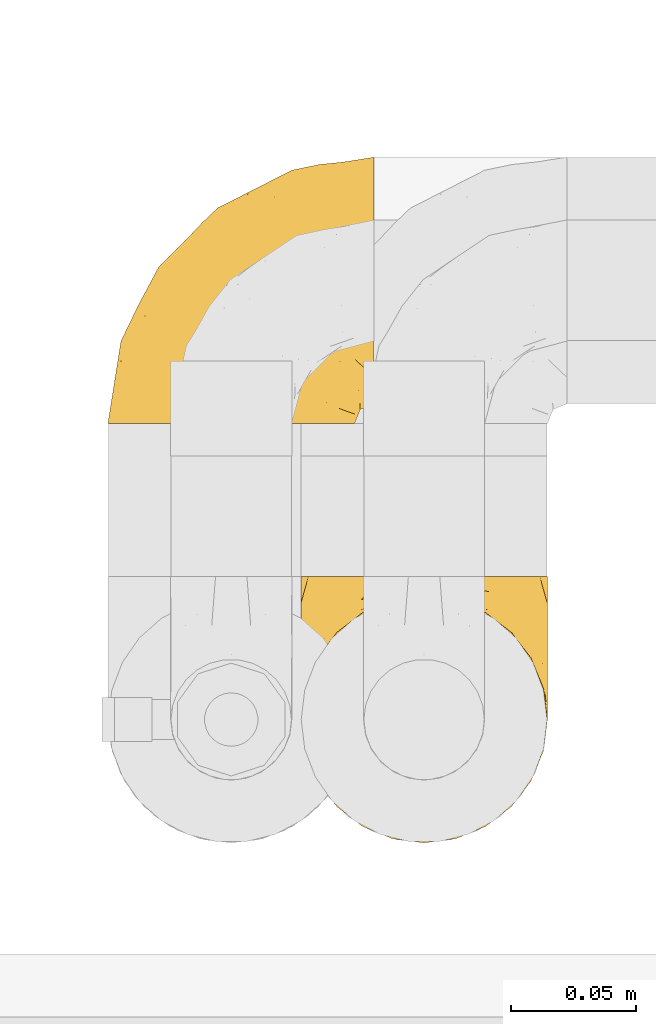
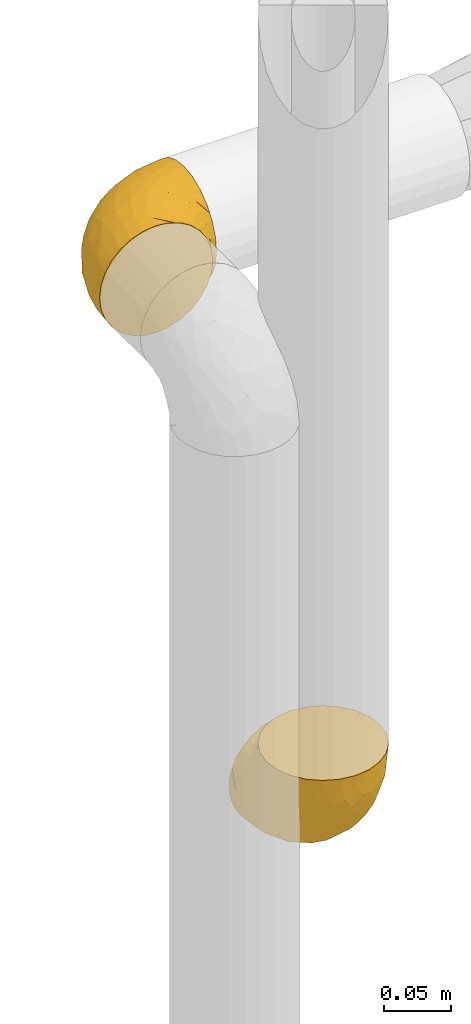
# One storey, part 409 of 827: 2 coverings.
"""IFC2X3 building model written with IfcOpenShell, lengths in millimetres."""

from ifc_helpers import new_model, entity, si_unit, converted_unit, derived_unit, direction, frame, origin, place, context, subcontext, project, spatial, faceted_brep, element, save


model = new_model("IFC2X3")

# Units and contexts
model_context = context("Model", 3, precision=0.01, world=origin(), true_north=direction((6.12303176911189e-17, 1.0)))
body_context = subcontext(model_context, "Body", "Model", "MODEL_VIEW")
ifc_project = project(units=[si_unit("LENGTHUNIT", "METRE", prefix="MILLI"), si_unit("AREAUNIT", "SQUARE_METRE"), si_unit("VOLUMEUNIT", "CUBIC_METRE"), converted_unit("PLANEANGLEUNIT", "DEGREE", entity("IfcRatioMeasure", 0.0174532925199433), si_unit("PLANEANGLEUNIT", "RADIAN"), dimensions=[0, 0, 0, 0, 0, 0, 0]), si_unit("MASSUNIT", "GRAM", prefix="KILO"), derived_unit("MASSDENSITYUNIT", [(si_unit("MASSUNIT", "GRAM", prefix="KILO"), 1), (si_unit("LENGTHUNIT", "METRE"), -3)]), derived_unit("MOMENTOFINERTIAUNIT", [(si_unit("LENGTHUNIT", "METRE"), 4)]), si_unit("TIMEUNIT", "SECOND"), si_unit("FREQUENCYUNIT", "HERTZ"), si_unit("THERMODYNAMICTEMPERATUREUNIT", "DEGREE_CELSIUS"), derived_unit("THERMALTRANSMITTANCEUNIT", [(si_unit("MASSUNIT", "GRAM", prefix="KILO"), 1), (si_unit("THERMODYNAMICTEMPERATUREUNIT", "KELVIN"), -1), (si_unit("TIMEUNIT", "SECOND"), -3)]), derived_unit("VOLUMETRICFLOWRATEUNIT", [(si_unit("LENGTHUNIT", "METRE"), 3), (si_unit("TIMEUNIT", "SECOND"), -1)]), derived_unit("MASSFLOWRATEUNIT", [(si_unit("MASSUNIT", "GRAM", prefix="KILO"), 1), (si_unit("TIMEUNIT", "SECOND"), -1)]), derived_unit("ROTATIONALFREQUENCYUNIT", [(si_unit("TIMEUNIT", "SECOND"), -1)]), si_unit("ELECTRICCURRENTUNIT", "AMPERE"), si_unit("ELECTRICVOLTAGEUNIT", "VOLT"), si_unit("POWERUNIT", "WATT"), si_unit("FORCEUNIT", "NEWTON", prefix="KILO"), si_unit("ILLUMINANCEUNIT", "LUX"), si_unit("LUMINOUSFLUXUNIT", "LUMEN"), si_unit("LUMINOUSINTENSITYUNIT", "CANDELA"), derived_unit("USERDEFINED", [(si_unit("MASSUNIT", "GRAM", prefix="KILO"), -1), (si_unit("LENGTHUNIT", "METRE"), -2), (si_unit("TIMEUNIT", "SECOND"), 3), (si_unit("LUMINOUSFLUXUNIT", "LUMEN"), 1)]), derived_unit("LINEARVELOCITYUNIT", [(si_unit("LENGTHUNIT", "METRE"), 1), (si_unit("TIMEUNIT", "SECOND"), -1)]), si_unit("PRESSUREUNIT", "PASCAL"), derived_unit("USERDEFINED", [(si_unit("LENGTHUNIT", "METRE"), -2), (si_unit("MASSUNIT", "GRAM", prefix="KILO"), 1), (si_unit("TIMEUNIT", "SECOND"), -2)]), derived_unit("LINEARFORCEUNIT", [(si_unit("MASSUNIT", "GRAM", prefix="KILO"), 1), (si_unit("LENGTHUNIT", "METRE"), 1), (si_unit("TIMEUNIT", "SECOND"), -2), (si_unit("LENGTHUNIT", "METRE"), -1)]), derived_unit("PLANARFORCEUNIT", [(si_unit("MASSUNIT", "GRAM", prefix="KILO"), 1), (si_unit("LENGTHUNIT", "METRE"), 1), (si_unit("TIMEUNIT", "SECOND"), -2), (si_unit("LENGTHUNIT", "METRE"), -2)])], contexts=[model_context])

# Site, building, storey
site_placement = place(None, origin())
site = spatial("IfcSite", under=ifc_project, at=site_placement, CompositionType="ELEMENT")
building_placement = place(site_placement, origin())
building = spatial("IfcBuilding", under=site, at=building_placement, CompositionType="ELEMENT")
storey_placement = place(building_placement, frame((0.0, 0.0, 28200.0)))
storey = spatial("IfcBuildingStorey", under=building, at=storey_placement, Name="08", CompositionType="ELEMENT", Elevation=28200.0)

# Coverings
covering_1_placement = place(storey_placement, frame((47610.43, 18915.48, 811.13)))
element("IfcCovering", 1, at=covering_1_placement, inside=storey, Name=":ADSK_", ObjectType=":ADSK_", PredefinedType="INSULATION", context=body_context, shape_type="Brep", body=[
    faceted_brep([(99.9, 107.75, 50.75), (98.66, 107.75, 39.8), (95.02, 107.75, 29.41), (89.17, 107.75, 20.09), (81.38, 107.75, 12.31), (72.06, 107.75, 6.46), (61.68, 107.75, 2.83), (50.75, 107.75, 1.6), (39.8, 107.75, 2.83), (29.41, 107.75, 6.47), (20.09, 107.75, 12.32), (12.31, 107.75, 20.11), (6.46, 107.75, 29.43), (2.83, 107.75, 39.81), (1.6, 107.75, 50.75), (2.24, 107.75, 56.45), (2.83, 107.75, 61.69), (4.65, 107.75, 66.88), (6.47, 107.75, 72.08), (12.32, 107.75, 81.4), (20.11, 107.75, 89.18), (29.43, 107.75, 95.03), (39.81, 107.75, 98.66), (50.75, 107.75, 99.9), (61.69, 107.75, 98.66), (72.08, 107.75, 95.02), (81.4, 107.75, 89.17), (89.18, 107.75, 81.38), (95.03, 107.75, 72.06), (96.85, 107.75, 66.87), (98.66, 107.75, 61.68), (99.25, 107.75, 56.45), (99.57, 107.75, 53.6), (38.02, 98.22, 107.75), (26.17, 93.31, 107.75), (21.08, 89.4, 107.75), (15.99, 85.5, 107.75), (12.09, 80.41, 107.75), (8.18, 75.32, 107.75), (5.73, 69.39, 107.75), (3.27, 63.47, 107.75), (2.35, 56.48, 107.75), (1.97, 53.61, 107.75), (1.6, 50.75, 107.75), (3.27, 38.02, 107.75), (8.18, 26.17, 107.75), (15.99, 15.99, 107.75), (26.17, 8.18, 107.75), (38.02, 3.27, 107.75), (50.75, 1.6, 107.75), (63.47, 3.27, 107.75), (75.32, 8.18, 107.75), (85.5, 15.99, 107.75), (93.31, 26.17, 107.75), (98.22, 38.02, 107.75), (99.9, 50.75, 107.75), (99.14, 56.48, 107.75), (98.22, 63.47, 107.75), (95.77, 69.39, 107.75), (93.31, 75.32, 107.75), (89.4, 80.41, 107.75), (85.5, 85.5, 107.75), (80.41, 89.4, 107.75), (75.32, 93.31, 107.75), (63.47, 98.22, 107.75), (50.75, 99.9, 107.75), (59.31, 27.53, 39.38), (73.08, 25.32, 49.75), (63.72, 16.29, 57.38), (50.75, 6.79, 74.94), (58.64, 4.51, 85.97), (50.75, 3.51, 95.66), (76.74, 17.47, 67.82), (67.68, 7.6, 83.09), (78.92, 12.27, 89.16), (94.31, 70.89, 37.01), (98.76, 87.17, 43.46), (98.4, 67.3, 51.79), (94.57, 31.65, 85.58), (89.91, 33.58, 62.84), (96.32, 47.23, 62.77), (98.79, 43.26, 88.17), (99.9, 55.08, 85.93), (99.9, 53.99, 91.42), (99.9, 52.9, 96.91), (99.9, 52.36, 99.62), (99.9, 51.82, 102.33), (87.31, 21.5, 82.57), (95.61, 89.94, 32.75), (60.43, 60.45, 13.79), (65.24, 83.0, 6.77), (72.87, 64.79, 16.46), (99.9, 85.93, 55.08), (99.9, 81.31, 58.17), (99.9, 76.69, 61.26), (99.9, 72.06, 64.35), (99.9, 67.44, 67.44), (90.65, 88.74, 24.18), (63.14, 45.98, 23.37), (91.89, 47.13, 49.76), (75.25, 89.4, 9.84), (50.75, 95.66, 3.51), (82.18, 28.5, 55.75), (85.08, 42.81, 42.34), (76.93, 38.28, 37.78), (50.75, 45.35, 21.87), (50.75, 33.61, 33.61), (83.02, 82.57, 17.1), (99.9, 105.04, 51.28), (99.9, 102.33, 51.82), (99.9, 96.91, 52.9), (99.9, 91.42, 53.99), (87.13, 65.92, 28.01), (80.85, 53.11, 28.99), (99.17, 54.37, 69.9), (50.75, 74.94, 6.79), (99.9, 64.35, 72.06), (99.9, 61.26, 76.69), (99.9, 58.17, 81.31), (50.75, 21.87, 45.35), (67.61, 34.79, 34.79), (72.25, 48.48, 25.72), (50.75, 60.15, 14.33), (50.75, 14.33, 60.15), (98.69, 99.07, 62.38), (99.01, 60.55, 100.57), (98.79, 64.18, 91.06), (98.29, 64.36, 97.66), (68.51, 103.17, 97.55), (76.82, 101.69, 93.65), (98.54, 87.75, 66.85), (99.3, 89.38, 61.93), (83.57, 88.34, 101.4), (89.47, 82.14, 100.07), (75.76, 94.51, 101.36), (84.86, 89.64, 95.94), (75.89, 98.41, 96.3), (64.77, 99.71, 101.98), (90.83, 89.37, 85.88), (94.62, 88.21, 78.88), (90.37, 95.2, 82.8), (91.18, 79.14, 102.58), (88.65, 101.22, 82.88), (84.11, 99.41, 88.57), (91.75, 84.72, 88.67), (96.86, 97.47, 69.08), (50.75, 102.19, 102.19), (58.97, 104.02, 100.06), (98.37, 82.66, 70.56), (83.91, 95.42, 91.07), (97.52, 78.67, 77.56), (95.55, 72.69, 96.59), (98.76, 66.46, 86.38), (95.26, 75.3, 91.79), (98.04, 72.74, 81.71), (90.65, 82.93, 94.11), (93.51, 99.27, 76.09), (94.16, 93.51, 76.91), (99.1, 67.35, 81.44), (25.73, 94.51, 101.37), (10.84, 82.94, 94.12), (17.92, 88.33, 101.41), (16.64, 89.64, 95.96), (30.44, 103.62, 96.22), (2.95, 87.74, 66.85), (2.19, 89.38, 61.94), (1.6, 81.31, 58.17), (4.63, 97.47, 69.1), (17.39, 99.41, 88.58), (1.6, 52.9, 96.91), (1.6, 51.82, 102.33), (1.6, 51.28, 105.04), (12.86, 101.21, 82.9), (11.13, 95.19, 82.82), (3.2, 64.36, 97.66), (5.94, 72.69, 96.59), (12.02, 82.13, 100.07), (6.23, 75.3, 91.79), (10.31, 79.14, 102.58), (8.0, 99.28, 76.13), (7.34, 93.51, 76.93), (2.48, 60.55, 100.57), (2.73, 66.46, 86.38), (2.64, 63.96, 90.86), (1.6, 96.91, 52.9), (2.8, 99.06, 62.39), (36.71, 99.7, 101.98), (1.6, 53.99, 91.42), (1.6, 55.08, 85.93), (38.59, 103.3, 99.49), (1.6, 102.33, 51.82), (1.6, 99.62, 52.36), (1.6, 76.69, 61.26), (3.12, 82.66, 70.56), (17.59, 95.42, 91.09), (1.6, 72.06, 64.35), (3.98, 78.68, 77.6), (6.87, 88.2, 78.89), (3.45, 72.75, 81.71), (9.76, 84.74, 88.69), (1.6, 91.42, 53.99), (1.6, 85.93, 55.08), (25.62, 98.41, 96.31), (10.67, 89.37, 85.9), (2.39, 67.35, 81.45), (1.6, 61.26, 76.69), (1.6, 58.17, 81.31), (1.6, 64.35, 72.06), (1.6, 67.44, 67.44), (2.4, 54.08, 69.6), (42.85, 4.51, 85.97), (14.18, 21.5, 82.57), (11.56, 33.43, 63.16), (19.27, 28.5, 55.81), (24.75, 17.47, 67.81), (28.37, 25.36, 49.73), (5.95, 90.18, 32.55), (2.79, 86.97, 43.23), (2.71, 43.26, 88.17), (37.78, 16.29, 57.38), (33.81, 7.6, 83.08), (22.57, 12.27, 89.16), (6.92, 31.65, 85.58), (28.61, 64.79, 16.46), (36.24, 83.0, 6.77), (41.05, 60.44, 13.8), (24.55, 38.35, 37.71), (33.88, 34.8, 34.8), (7.11, 71.54, 36.83), (42.18, 27.53, 39.38), (18.46, 82.57, 17.12), (10.84, 88.74, 24.19), (20.69, 53.19, 28.89), (29.27, 48.49, 25.69), (3.1, 67.28, 51.77), (9.18, 52.32, 45.66), (38.38, 45.94, 23.39), (26.23, 89.4, 9.85), (14.34, 65.75, 28.11), (5.46, 46.73, 62.27), (16.39, 42.82, 42.35)], [[[0, 1, 2, 3, 4, 5, 6, 7, 8, 9, 10, 11, 12, 13, 14, 15, 16, 17, 18, 19, 20, 21, 22, 23, 24, 25, 26, 27, 28, 29, 30, 31, 32]], [[33, 34, 35, 36, 37, 38, 39, 40, 41, 42, 43, 44, 45, 46, 47, 48, 49, 50, 51, 52, 53, 54, 55, 56, 57, 58, 59, 60, 61, 62, 63, 64, 65]], [[66, 67, 68]], [[69, 70, 71]], [[68, 72, 73]], [[73, 72, 74]], [[75, 76, 77]], [[78, 79, 80]], [[51, 50, 73]], [[81, 82, 83, 84, 85, 86, 55]], [[52, 87, 53]], [[74, 52, 51]], [[2, 1, 88]], [[89, 90, 91]], [[77, 92, 93, 94, 95, 96]], [[55, 54, 81]], [[78, 53, 87]], [[5, 90, 6]], [[88, 76, 75]], [[97, 3, 2]], [[89, 91, 98]], [[99, 80, 79]], [[90, 5, 100]], [[74, 87, 52]], [[100, 5, 4]], [[90, 101, 6]], [[79, 102, 103]], [[102, 67, 104]], [[105, 98, 106]], [[107, 4, 3]], [[76, 0, 108, 109, 110, 111, 92]], [[107, 112, 113]], [[114, 77, 96]], [[89, 115, 90]], [[114, 96, 116, 117, 118, 82]], [[75, 97, 88]], [[119, 66, 68]], [[50, 71, 70]], [[100, 91, 90]], [[99, 77, 80]], [[102, 104, 103]], [[97, 107, 3]], [[80, 81, 78]], [[107, 97, 112]], [[68, 73, 70]], [[66, 98, 120]], [[78, 81, 54]], [[114, 81, 80]], [[53, 78, 54]], [[78, 87, 79]], [[102, 87, 72]], [[79, 103, 99]], [[4, 107, 100]], [[91, 100, 107]], [[88, 97, 2]], [[112, 97, 75]], [[99, 112, 75]], [[103, 104, 113]], [[91, 121, 98]], [[89, 105, 122, 115]], [[101, 90, 115]], [[101, 7, 6]], [[88, 1, 76]], [[0, 76, 1]], [[92, 77, 76]], [[73, 74, 51]], [[87, 74, 72]], [[81, 114, 82]], [[77, 114, 80]], [[87, 102, 79]], [[67, 102, 72]], [[68, 67, 72]], [[67, 120, 104]], [[120, 121, 104]], [[104, 121, 113]], [[121, 120, 98]], [[91, 107, 113]], [[91, 113, 121]], [[103, 113, 112]], [[66, 119, 106]], [[105, 89, 98]], [[68, 69, 123, 119]], [[98, 66, 106]], [[66, 120, 67]], [[50, 49, 71]], [[50, 70, 73]], [[112, 99, 103]], [[77, 99, 75]], [[69, 68, 70]], [[29, 124, 110]], [[84, 83, 125]], [[126, 82, 118]], [[59, 58, 127]], [[25, 128, 129]], [[130, 93, 131]], [[132, 62, 133]], [[134, 135, 136]], [[137, 65, 64]], [[64, 134, 137]], [[138, 139, 140]], [[111, 110, 124, 92]], [[134, 136, 137]], [[134, 64, 63]], [[133, 61, 141]], [[125, 58, 57]], [[142, 143, 140]], [[142, 26, 143]], [[127, 83, 82]], [[28, 124, 29]], [[108, 0, 32, 31, 30, 110, 109]], [[30, 29, 110]], [[135, 144, 138]], [[28, 145, 124]], [[57, 56, 55, 86, 85, 84]], [[146, 147, 23]], [[24, 23, 147]], [[25, 143, 26]], [[95, 94, 148]], [[24, 128, 25]], [[149, 138, 143]], [[124, 145, 131]], [[127, 58, 125]], [[150, 148, 139]], [[127, 126, 151]], [[151, 59, 127]], [[152, 151, 126]], [[153, 154, 155]], [[153, 133, 141]], [[145, 28, 27]], [[142, 156, 27]], [[157, 148, 130]], [[61, 133, 62]], [[134, 132, 135]], [[147, 128, 24]], [[65, 137, 146]], [[146, 137, 147]], [[128, 137, 136]], [[137, 128, 147]], [[128, 136, 129]], [[149, 129, 136]], [[25, 129, 143]], [[158, 152, 117]], [[152, 118, 117]], [[153, 151, 152]], [[158, 116, 154]], [[144, 150, 138]], [[153, 152, 158]], [[133, 153, 155]], [[133, 155, 132]], [[141, 61, 60]], [[135, 132, 155]], [[134, 63, 132]], [[144, 135, 155]], [[135, 138, 149]], [[155, 154, 144]], [[150, 154, 96]], [[154, 150, 144]], [[148, 94, 130]], [[82, 126, 127]], [[118, 152, 126]], [[150, 96, 95]], [[139, 148, 157]], [[150, 95, 148]], [[93, 92, 131]], [[130, 145, 156]], [[130, 94, 93]], [[84, 125, 57]], [[127, 125, 83]], [[140, 139, 157]], [[150, 139, 138]], [[140, 157, 142]], [[138, 140, 143]], [[156, 142, 157]], [[27, 26, 142]], [[130, 156, 157]], [[145, 27, 156]], [[132, 63, 62]], [[124, 131, 92]], [[130, 131, 145]], [[129, 149, 143]], [[135, 149, 136]], [[60, 151, 141]], [[59, 151, 60]], [[141, 151, 153]], [[116, 96, 154]], [[153, 158, 154]], [[158, 117, 116]], [[34, 33, 159]], [[160, 161, 162]], [[22, 21, 163]], [[164, 165, 166]], [[19, 18, 167]], [[168, 21, 20]], [[42, 41, 40, 169, 170, 171, 43]], [[172, 173, 168]], [[174, 38, 175]], [[176, 177, 178]], [[179, 164, 180]], [[40, 181, 169]], [[182, 183, 175]], [[17, 184, 185]], [[65, 146, 186]], [[187, 174, 188]], [[23, 22, 189]], [[174, 39, 38]], [[15, 14, 190, 191, 184, 16]], [[181, 40, 39]], [[192, 193, 164]], [[194, 163, 168]], [[33, 186, 159]], [[180, 173, 172]], [[195, 196, 193]], [[18, 185, 167]], [[173, 180, 197]], [[198, 199, 196]], [[200, 201, 185, 184]], [[184, 17, 16]], [[18, 17, 185]], [[202, 159, 186]], [[194, 168, 203]], [[189, 163, 202]], [[204, 205, 182]], [[187, 181, 174]], [[160, 177, 176]], [[206, 183, 182]], [[206, 182, 205]], [[201, 165, 185]], [[165, 164, 167]], [[172, 179, 180]], [[202, 194, 162]], [[176, 161, 160]], [[65, 186, 33]], [[163, 189, 22]], [[175, 177, 182]], [[174, 183, 188]], [[177, 198, 204]], [[199, 160, 162]], [[198, 207, 204]], [[175, 38, 37]], [[198, 177, 160]], [[178, 177, 175]], [[176, 35, 161]], [[34, 159, 161]], [[162, 161, 159]], [[202, 162, 159]], [[199, 162, 203]], [[196, 199, 203]], [[198, 160, 199]], [[193, 197, 180]], [[208, 198, 196]], [[188, 183, 206]], [[175, 183, 174]], [[193, 192, 195]], [[195, 208, 196]], [[197, 196, 203]], [[180, 164, 193]], [[168, 163, 21]], [[166, 165, 201]], [[166, 192, 164]], [[189, 202, 186]], [[186, 146, 189]], [[23, 189, 146]], [[174, 181, 39]], [[169, 181, 187]], [[196, 197, 193]], [[173, 203, 168]], [[203, 173, 197]], [[172, 168, 20]], [[20, 19, 172]], [[179, 172, 19]], [[19, 167, 179]], [[164, 179, 167]], [[35, 176, 36]], [[35, 34, 161]], [[185, 165, 167]], [[162, 194, 203]], [[163, 194, 202]], [[176, 178, 36]], [[37, 36, 178]], [[175, 37, 178]], [[177, 204, 182]], [[207, 198, 208]], [[207, 205, 204]], [[209, 188, 206, 205, 207, 208]], [[48, 210, 71]], [[211, 212, 213]], [[214, 213, 215]], [[216, 217, 13]], [[218, 43, 171, 170, 169, 187, 188]], [[219, 220, 214]], [[47, 46, 221]], [[210, 48, 220]], [[211, 222, 212]], [[222, 45, 44]], [[221, 220, 47]], [[47, 220, 48]], [[221, 211, 214]], [[223, 224, 225]], [[211, 46, 45]], [[226, 227, 215]], [[43, 218, 44]], [[217, 216, 228]], [[215, 229, 219]], [[14, 13, 217]], [[224, 9, 8]], [[10, 230, 11]], [[11, 231, 12]], [[232, 223, 233]], [[234, 208, 195, 192, 166, 201]], [[235, 234, 228]], [[222, 44, 218]], [[106, 229, 236]], [[224, 237, 9]], [[231, 238, 228]], [[9, 237, 10]], [[115, 224, 101]], [[239, 234, 235]], [[231, 11, 230]], [[223, 230, 237]], [[224, 8, 101]], [[223, 236, 233]], [[225, 115, 122, 105]], [[216, 12, 231]], [[209, 234, 239]], [[210, 219, 69]], [[219, 214, 215]], [[229, 119, 219]], [[209, 218, 188]], [[239, 212, 222]], [[239, 222, 218]], [[45, 222, 211]], [[235, 212, 239]], [[213, 212, 240]], [[223, 237, 224]], [[230, 10, 237]], [[238, 231, 230]], [[216, 231, 228]], [[232, 230, 223]], [[235, 238, 240]], [[115, 225, 224]], [[233, 236, 227]], [[8, 7, 101]], [[234, 209, 208]], [[218, 209, 239]], [[217, 228, 234]], [[13, 12, 216]], [[234, 201, 217]], [[217, 201, 200, 184, 191, 190, 14]], [[211, 221, 46]], [[220, 221, 214]], [[71, 210, 69]], [[71, 49, 48]], [[219, 210, 220]], [[226, 215, 213]], [[211, 213, 214]], [[226, 213, 240]], [[215, 227, 229]], [[232, 240, 238]], [[233, 227, 226]], [[232, 233, 226]], [[236, 223, 225]], [[240, 232, 226]], [[232, 238, 230]], [[225, 105, 236]], [[236, 105, 106]], [[229, 106, 119]], [[69, 219, 119, 123]], [[236, 229, 227]], [[238, 235, 228]], [[212, 235, 240]]]),
])
covering_2_placement = place(storey_placement, frame((47533.55, 19082.63, 1249.25)))
element("IfcCovering", 2, at=covering_2_placement, inside=storey, Name=":ADSK_", ObjectType=":ADSK_", PredefinedType="INSULATION", context=body_context, shape_type="Brep", body=[
    faceted_brep([(50.75, 1.6, 99.9), (39.8, 1.6, 98.66), (29.41, 1.6, 95.02), (20.09, 1.6, 89.17), (12.31, 1.6, 81.38), (6.46, 1.6, 72.06), (2.83, 1.6, 61.68), (1.6, 1.6, 50.75), (2.83, 1.6, 39.8), (6.47, 1.6, 29.41), (12.32, 1.6, 20.09), (20.11, 1.6, 12.31), (29.43, 1.6, 6.46), (39.81, 1.6, 2.83), (50.75, 1.6, 1.6), (56.45, 1.6, 2.24), (61.69, 1.6, 2.83), (66.88, 1.6, 4.65), (72.08, 1.6, 6.47), (81.4, 1.6, 12.32), (89.18, 1.6, 20.11), (95.03, 1.6, 29.43), (98.66, 1.6, 39.81), (99.9, 1.6, 50.75), (98.66, 1.6, 61.69), (95.02, 1.6, 72.08), (89.17, 1.6, 81.4), (81.38, 1.6, 89.18), (72.06, 1.6, 95.03), (66.87, 1.6, 96.85), (61.68, 1.6, 98.66), (56.45, 1.6, 99.25), (53.6, 1.6, 99.57), (107.75, 11.12, 38.02), (107.75, 16.03, 26.17), (107.75, 19.94, 21.08), (107.75, 23.84, 15.99), (107.75, 28.93, 12.09), (107.75, 34.02, 8.18), (107.75, 39.95, 5.73), (107.75, 45.87, 3.27), (107.75, 52.86, 2.35), (107.75, 55.73, 1.97), (107.75, 58.6, 1.6), (107.75, 71.32, 3.27), (107.75, 83.17, 8.18), (107.75, 93.35, 15.99), (107.75, 101.16, 26.17), (107.75, 106.07, 38.02), (107.75, 107.75, 50.75), (107.75, 106.07, 63.47), (107.75, 101.16, 75.32), (107.75, 93.35, 85.5), (107.75, 83.17, 93.31), (107.75, 71.32, 98.22), (107.75, 58.6, 99.9), (107.75, 52.86, 99.14), (107.75, 45.87, 98.22), (107.75, 39.95, 95.77), (107.75, 34.02, 93.31), (107.75, 28.93, 89.4), (107.75, 23.84, 85.5), (107.75, 19.94, 80.41), (107.75, 16.03, 75.32), (107.75, 11.12, 63.47), (107.75, 9.45, 50.75), (39.38, 81.82, 59.31), (49.75, 84.02, 73.08), (57.38, 93.05, 63.72), (74.94, 102.55, 50.75), (85.97, 104.83, 58.64), (95.66, 105.83, 50.75), (67.82, 91.87, 76.74), (83.09, 101.74, 67.68), (89.16, 97.07, 78.92), (37.01, 38.45, 94.31), (43.46, 22.17, 98.76), (51.79, 42.04, 98.4), (85.58, 77.69, 94.57), (62.84, 75.76, 89.91), (62.77, 62.11, 96.32), (88.17, 66.08, 98.79), (85.93, 54.26, 99.9), (91.42, 55.35, 99.9), (96.91, 56.44, 99.9), (99.62, 56.98, 99.9), (102.33, 57.52, 99.9), (82.57, 87.84, 87.31), (32.75, 19.41, 95.61), (13.79, 48.89, 60.43), (6.77, 26.34, 65.24), (16.46, 44.55, 72.87), (55.08, 23.41, 99.9), (58.17, 28.03, 99.9), (61.26, 32.65, 99.9), (64.35, 37.28, 99.9), (67.44, 41.9, 99.9), (24.18, 20.6, 90.65), (23.37, 63.36, 63.14), (49.76, 62.21, 91.89), (9.84, 19.94, 75.25), (3.51, 13.68, 50.75), (55.75, 80.85, 82.18), (42.34, 66.53, 85.08), (37.78, 71.06, 76.93), (21.87, 63.99, 50.75), (33.61, 75.73, 50.75), (17.1, 26.77, 83.02), (51.28, 4.31, 99.9), (51.82, 7.01, 99.9), (52.9, 12.43, 99.9), (53.99, 17.92, 99.9), (28.01, 43.43, 87.13), (28.99, 56.23, 80.85), (69.9, 54.97, 99.17), (6.79, 34.4, 50.75), (72.06, 44.99, 99.9), (76.69, 48.08, 99.9), (81.31, 51.17, 99.9), (45.35, 87.47, 50.75), (34.79, 74.55, 67.61), (25.72, 60.86, 72.25), (14.33, 49.19, 50.75), (60.15, 95.01, 50.75), (62.38, 10.27, 98.69), (100.57, 48.79, 99.01), (91.06, 45.16, 98.79), (97.66, 44.99, 98.29), (97.55, 6.17, 68.51), (93.65, 7.65, 76.82), (66.85, 21.59, 98.54), (61.93, 19.96, 99.3), (101.4, 21.0, 83.57), (100.07, 27.2, 89.47), (101.36, 14.83, 75.76), (95.94, 19.7, 84.86), (96.3, 10.93, 75.89), (101.98, 9.63, 64.77), (85.88, 19.97, 90.83), (78.88, 21.13, 94.62), (82.8, 14.14, 90.37), (102.58, 30.2, 91.18), (82.88, 8.12, 88.65), (88.57, 9.93, 84.11), (88.67, 24.62, 91.75), (69.08, 11.87, 96.86), (102.19, 7.15, 50.75), (100.06, 5.32, 58.97), (70.56, 26.68, 98.37), (91.07, 13.92, 83.91), (77.56, 30.67, 97.52), (96.59, 36.65, 95.55), (86.38, 42.89, 98.76), (91.79, 34.04, 95.26), (81.71, 36.6, 98.04), (94.11, 26.41, 90.65), (76.09, 10.07, 93.51), (76.91, 15.83, 94.16), (81.44, 41.99, 99.1), (101.37, 14.83, 25.73), (94.12, 26.4, 10.84), (101.41, 21.01, 17.92), (95.96, 19.71, 16.64), (96.22, 5.72, 30.44), (66.85, 21.6, 2.95), (61.94, 19.96, 2.19), (58.17, 28.03, 1.6), (69.1, 11.87, 4.63), (88.58, 9.93, 17.39), (96.91, 56.44, 1.6), (102.33, 57.52, 1.6), (105.04, 58.06, 1.6), (82.9, 8.13, 12.86), (82.82, 14.15, 11.13), (97.66, 44.99, 3.2), (96.59, 36.65, 5.94), (100.07, 27.21, 12.02), (91.79, 34.04, 6.23), (102.58, 30.2, 10.31), (76.13, 10.06, 8.0), (76.93, 15.83, 7.34), (100.57, 48.79, 2.48), (86.38, 42.89, 2.73), (90.86, 45.38, 2.64), (52.9, 12.43, 1.6), (62.39, 10.28, 2.8), (101.98, 9.64, 36.71), (91.42, 55.35, 1.6), (85.93, 54.26, 1.6), (99.49, 6.05, 38.59), (51.82, 7.01, 1.6), (52.36, 9.72, 1.6), (61.26, 32.65, 1.6), (70.56, 26.68, 3.12), (91.09, 13.92, 17.59), (64.35, 37.28, 1.6), (77.6, 30.66, 3.98), (78.89, 21.14, 6.87), (81.71, 36.59, 3.45), (88.69, 24.6, 9.76), (53.99, 17.92, 1.6), (55.08, 23.41, 1.6), (96.31, 10.93, 25.62), (85.9, 19.97, 10.67), (81.45, 41.99, 2.39), (76.69, 48.08, 1.6), (81.31, 51.17, 1.6), (72.06, 44.99, 1.6), (67.44, 41.9, 1.6), (69.6, 55.26, 2.4), (85.97, 104.83, 42.85), (82.57, 87.84, 14.18), (63.16, 75.91, 11.56), (55.81, 80.84, 19.27), (67.81, 91.87, 24.75), (49.73, 83.98, 28.37), (32.55, 19.16, 5.95), (43.23, 22.37, 2.79), (88.17, 66.08, 2.71), (57.38, 93.05, 37.78), (83.08, 101.74, 33.81), (89.16, 97.07, 22.57), (85.58, 77.69, 6.92), (16.46, 44.55, 28.61), (6.77, 26.34, 36.24), (13.8, 48.9, 41.05), (37.71, 70.99, 24.55), (34.8, 74.55, 33.88), (36.83, 37.8, 7.11), (39.38, 81.82, 42.18), (17.12, 26.77, 18.46), (24.19, 20.6, 10.84), (28.89, 56.15, 20.69), (25.69, 60.85, 29.27), (51.77, 42.06, 3.1), (45.66, 57.03, 9.18), (23.39, 63.4, 38.38), (9.85, 19.94, 26.23), (28.11, 43.59, 14.34), (62.27, 62.61, 5.46), (42.35, 66.52, 16.39)], [[[0, 1, 2, 3, 4, 5, 6, 7, 8, 9, 10, 11, 12, 13, 14, 15, 16, 17, 18, 19, 20, 21, 22, 23, 24, 25, 26, 27, 28, 29, 30, 31, 32]], [[33, 34, 35, 36, 37, 38, 39, 40, 41, 42, 43, 44, 45, 46, 47, 48, 49, 50, 51, 52, 53, 54, 55, 56, 57, 58, 59, 60, 61, 62, 63, 64, 65]], [[66, 67, 68]], [[69, 70, 71]], [[68, 72, 73]], [[73, 72, 74]], [[75, 76, 77]], [[78, 79, 80]], [[51, 50, 73]], [[81, 82, 83, 84, 85, 86, 55]], [[52, 87, 53]], [[74, 52, 51]], [[2, 1, 88]], [[89, 90, 91]], [[77, 92, 93, 94, 95, 96]], [[55, 54, 81]], [[78, 53, 87]], [[5, 90, 6]], [[88, 76, 75]], [[97, 3, 2]], [[89, 91, 98]], [[99, 80, 79]], [[90, 5, 100]], [[74, 87, 52]], [[100, 5, 4]], [[90, 101, 6]], [[79, 102, 103]], [[102, 67, 104]], [[105, 98, 106]], [[107, 4, 3]], [[76, 0, 108, 109, 110, 111, 92]], [[107, 112, 113]], [[114, 77, 96]], [[89, 115, 90]], [[114, 96, 116, 117, 118, 82]], [[75, 97, 88]], [[119, 66, 68]], [[50, 71, 70]], [[100, 91, 90]], [[99, 77, 80]], [[102, 104, 103]], [[97, 107, 3]], [[80, 81, 78]], [[107, 97, 112]], [[68, 73, 70]], [[66, 98, 120]], [[78, 81, 54]], [[114, 81, 80]], [[53, 78, 54]], [[78, 87, 79]], [[102, 87, 72]], [[79, 103, 99]], [[4, 107, 100]], [[91, 100, 107]], [[88, 97, 2]], [[112, 97, 75]], [[99, 112, 75]], [[103, 104, 113]], [[91, 121, 98]], [[89, 105, 122, 115]], [[101, 90, 115]], [[101, 7, 6]], [[88, 1, 76]], [[0, 76, 1]], [[92, 77, 76]], [[73, 74, 51]], [[87, 74, 72]], [[81, 114, 82]], [[77, 114, 80]], [[87, 102, 79]], [[67, 102, 72]], [[68, 67, 72]], [[67, 120, 104]], [[120, 121, 104]], [[104, 121, 113]], [[121, 120, 98]], [[91, 107, 113]], [[91, 113, 121]], [[103, 113, 112]], [[106, 98, 66]], [[105, 89, 98]], [[106, 66, 119]], [[67, 66, 120]], [[68, 69, 123, 119]], [[50, 49, 71]], [[50, 70, 73]], [[112, 99, 103]], [[77, 99, 75]], [[69, 68, 70]], [[29, 124, 110]], [[84, 83, 125]], [[126, 82, 118]], [[59, 58, 127]], [[25, 128, 129]], [[130, 93, 131]], [[132, 62, 133]], [[134, 135, 136]], [[137, 65, 64]], [[64, 134, 137]], [[138, 139, 140]], [[111, 110, 124, 92]], [[134, 136, 137]], [[134, 64, 63]], [[141, 61, 60]], [[125, 58, 57]], [[142, 143, 140]], [[142, 26, 143]], [[127, 83, 82]], [[28, 124, 29]], [[108, 0, 32, 31, 30, 110, 109]], [[30, 29, 110]], [[135, 144, 138]], [[28, 145, 124]], [[57, 56, 55, 86, 85, 84]], [[146, 147, 23]], [[24, 23, 147]], [[25, 143, 26]], [[95, 94, 148]], [[24, 128, 25]], [[149, 138, 143]], [[124, 145, 131]], [[127, 58, 125]], [[150, 148, 139]], [[127, 126, 151]], [[151, 59, 127]], [[152, 151, 126]], [[153, 154, 155]], [[153, 133, 141]], [[145, 28, 27]], [[142, 156, 27]], [[157, 148, 130]], [[61, 133, 62]], [[134, 132, 135]], [[147, 128, 24]], [[65, 137, 146]], [[146, 137, 147]], [[128, 137, 136]], [[137, 128, 147]], [[128, 136, 129]], [[149, 129, 136]], [[25, 129, 143]], [[158, 152, 117]], [[152, 118, 117]], [[153, 151, 152]], [[158, 116, 154]], [[144, 150, 138]], [[153, 152, 158]], [[133, 153, 155]], [[133, 155, 132]], [[60, 151, 141]], [[135, 132, 155]], [[134, 63, 132]], [[144, 135, 155]], [[135, 138, 149]], [[155, 154, 144]], [[150, 154, 96]], [[154, 150, 144]], [[148, 94, 130]], [[82, 126, 127]], [[118, 152, 126]], [[150, 96, 95]], [[139, 148, 157]], [[150, 95, 148]], [[93, 92, 131]], [[130, 145, 156]], [[130, 94, 93]], [[84, 125, 57]], [[127, 125, 83]], [[140, 139, 157]], [[150, 139, 138]], [[140, 157, 142]], [[138, 140, 143]], [[156, 142, 157]], [[27, 26, 142]], [[130, 156, 157]], [[145, 27, 156]], [[132, 63, 62]], [[124, 131, 92]], [[130, 131, 145]], [[129, 149, 143]], [[135, 149, 136]], [[141, 133, 61]], [[60, 59, 151]], [[141, 151, 153]], [[116, 96, 154]], [[153, 158, 154]], [[158, 117, 116]], [[34, 33, 159]], [[160, 161, 162]], [[22, 21, 163]], [[164, 165, 166]], [[19, 18, 167]], [[168, 21, 20]], [[42, 41, 40, 169, 170, 171, 43]], [[172, 173, 168]], [[174, 38, 175]], [[176, 177, 178]], [[179, 164, 180]], [[40, 181, 169]], [[182, 183, 175]], [[17, 184, 185]], [[65, 146, 186]], [[187, 174, 188]], [[23, 22, 189]], [[174, 39, 38]], [[15, 14, 190, 191, 184, 16]], [[181, 40, 39]], [[192, 193, 164]], [[194, 163, 168]], [[33, 186, 159]], [[180, 173, 172]], [[195, 196, 193]], [[18, 185, 167]], [[173, 180, 197]], [[198, 199, 196]], [[200, 201, 185, 184]], [[184, 17, 16]], [[18, 17, 185]], [[202, 159, 186]], [[194, 168, 203]], [[189, 163, 202]], [[204, 205, 182]], [[187, 181, 174]], [[160, 177, 176]], [[206, 183, 182]], [[206, 182, 205]], [[201, 165, 185]], [[165, 164, 167]], [[172, 179, 180]], [[202, 194, 162]], [[176, 161, 160]], [[65, 186, 33]], [[163, 189, 22]], [[175, 177, 182]], [[174, 183, 188]], [[177, 198, 204]], [[199, 160, 162]], [[198, 207, 204]], [[175, 38, 37]], [[198, 177, 160]], [[178, 177, 175]], [[176, 35, 161]], [[34, 159, 161]], [[162, 161, 159]], [[202, 162, 159]], [[199, 162, 203]], [[196, 199, 203]], [[198, 160, 199]], [[193, 197, 180]], [[208, 198, 196]], [[188, 183, 206]], [[175, 183, 174]], [[193, 192, 195]], [[195, 208, 196]], [[197, 196, 203]], [[180, 164, 193]], [[168, 163, 21]], [[166, 165, 201]], [[166, 192, 164]], [[189, 202, 186]], [[186, 146, 189]], [[23, 189, 146]], [[174, 181, 39]], [[169, 181, 187]], [[196, 197, 193]], [[173, 203, 168]], [[203, 173, 197]], [[172, 168, 20]], [[20, 19, 172]], [[179, 172, 19]], [[19, 167, 179]], [[164, 179, 167]], [[35, 176, 36]], [[35, 34, 161]], [[185, 165, 167]], [[162, 194, 203]], [[163, 194, 202]], [[176, 178, 36]], [[37, 36, 178]], [[175, 37, 178]], [[177, 204, 182]], [[207, 198, 208]], [[207, 205, 204]], [[209, 188, 206, 205, 207, 208]], [[48, 210, 71]], [[211, 212, 213]], [[214, 213, 215]], [[216, 217, 13]], [[218, 43, 171, 170, 169, 187, 188]], [[219, 220, 214]], [[47, 46, 221]], [[210, 48, 220]], [[211, 222, 212]], [[222, 45, 44]], [[221, 220, 47]], [[47, 220, 48]], [[221, 211, 214]], [[223, 224, 225]], [[211, 46, 45]], [[226, 227, 215]], [[43, 218, 44]], [[217, 216, 228]], [[219, 215, 229]], [[14, 13, 217]], [[224, 9, 8]], [[10, 230, 11]], [[11, 231, 12]], [[232, 223, 233]], [[234, 208, 195, 192, 166, 201]], [[235, 234, 228]], [[222, 44, 218]], [[106, 229, 236]], [[224, 237, 9]], [[231, 238, 228]], [[9, 237, 10]], [[115, 224, 101]], [[239, 234, 235]], [[231, 11, 230]], [[223, 230, 237]], [[224, 8, 101]], [[223, 236, 233]], [[225, 115, 122, 105]], [[216, 12, 231]], [[209, 234, 239]], [[210, 219, 69]], [[219, 214, 215]], [[229, 119, 219]], [[209, 218, 188]], [[239, 212, 222]], [[239, 222, 218]], [[45, 222, 211]], [[235, 212, 239]], [[213, 212, 240]], [[223, 237, 224]], [[230, 10, 237]], [[238, 231, 230]], [[216, 231, 228]], [[232, 230, 223]], [[235, 238, 240]], [[115, 225, 224]], [[233, 236, 227]], [[8, 7, 101]], [[234, 209, 208]], [[218, 209, 239]], [[217, 228, 234]], [[13, 12, 216]], [[234, 201, 217]], [[217, 201, 200, 184, 191, 190, 14]], [[211, 221, 46]], [[220, 221, 214]], [[71, 210, 69]], [[71, 49, 48]], [[219, 210, 220]], [[226, 215, 213]], [[211, 213, 214]], [[226, 213, 240]], [[215, 227, 229]], [[232, 240, 238]], [[233, 227, 226]], [[232, 233, 226]], [[236, 223, 225]], [[240, 232, 226]], [[232, 238, 230]], [[225, 105, 236]], [[236, 105, 106]], [[236, 229, 227]], [[123, 69, 219, 119]], [[106, 119, 229]], [[238, 235, 228]], [[212, 235, 240]]]),
])

save(model, "model.ifc")
